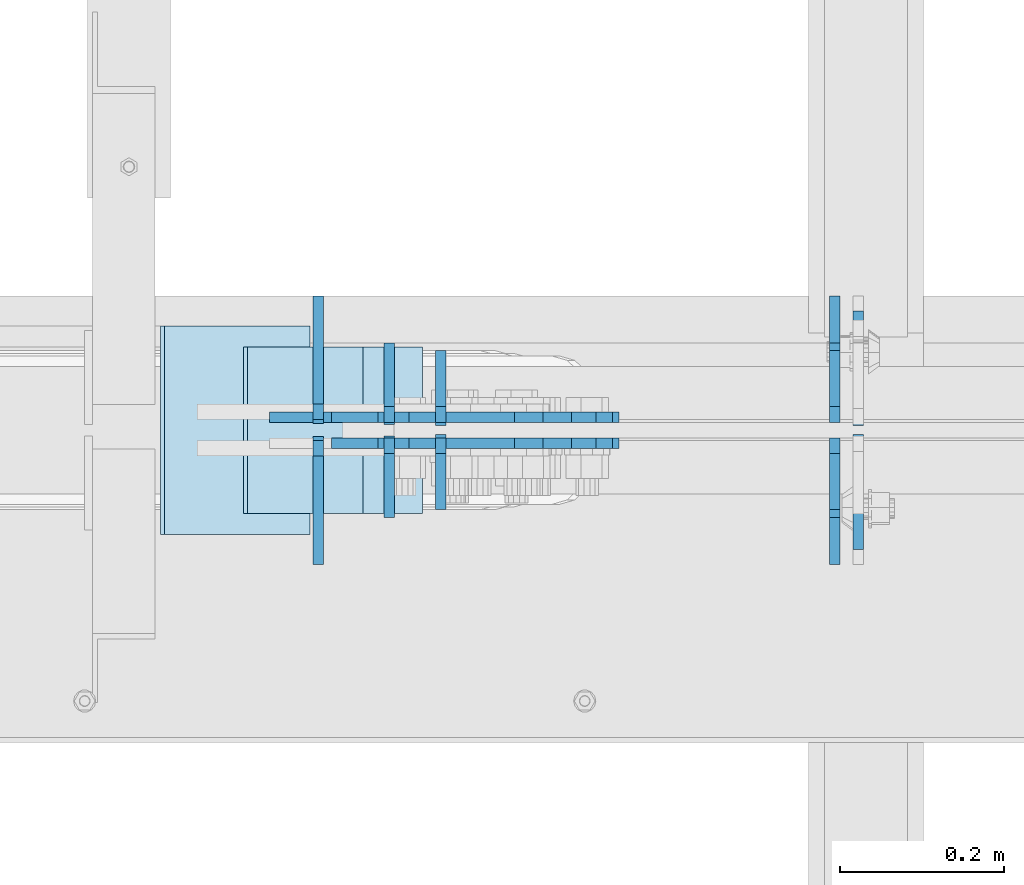
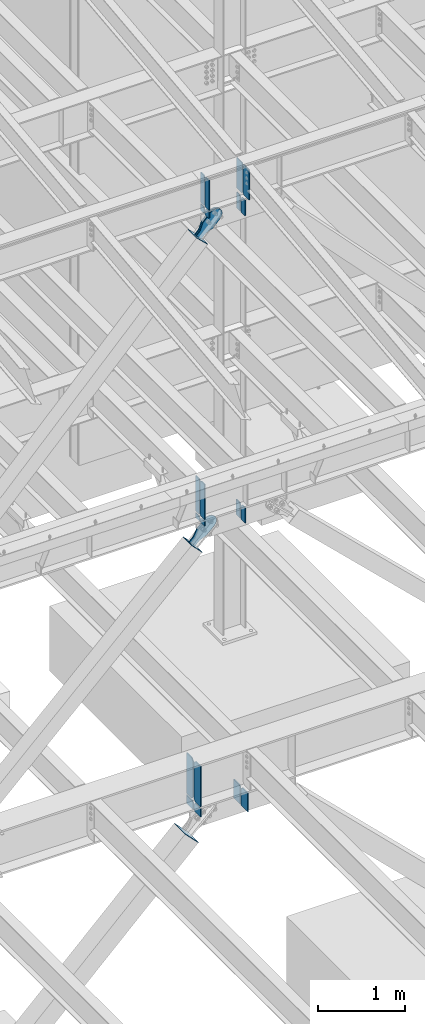
# One storey, part 1038 of 1179: 26 plates, 9 elements without a shape of their own.
"""IFC2X3 building model written with IfcOpenShell, lengths in millimetres."""

from ifc_helpers import new_model, si_unit, frame, origin_with_axes, place, context, subcontext, project, spatial, faceted_brep, material, type_object, element, aggregate, save


model = new_model("IFC2X3")

# Units and contexts
model_context = context("Model", 3, precision=1e-05, world=origin_with_axes())
body_context = subcontext(model_context, "Body", "Model", "MODEL_VIEW")
ifc_project = project(units=[si_unit("LENGTHUNIT", "METRE", prefix="MILLI"), si_unit("AREAUNIT", "SQUARE_METRE"), si_unit("VOLUMEUNIT", "CUBIC_METRE"), si_unit("MASSUNIT", "GRAM", prefix="KILO"), si_unit("TIMEUNIT", "SECOND"), si_unit("PLANEANGLEUNIT", "RADIAN"), si_unit("SOLIDANGLEUNIT", "STERADIAN"), si_unit("THERMODYNAMICTEMPERATUREUNIT", "DEGREE_CELSIUS"), si_unit("LUMINOUSINTENSITYUNIT", "LUMEN")], contexts=[model_context])

# Site, building, storey
site_placement = place(None, origin_with_axes())
site = spatial("IfcSite", under=ifc_project, at=site_placement, CompositionType="ELEMENT")
building_placement = place(site_placement, origin_with_axes())
building = spatial("IfcBuilding", under=site, at=building_placement, Name="Undefined", CompositionType="ELEMENT")
storey_placement = place(building_placement, origin_with_axes())
storey = spatial("IfcBuildingStorey", under=building, at=storey_placement, Name="Undefined", CompositionType="ELEMENT", Elevation=0.0)

# Assembly, plates
assembly_1_placement = place(storey_placement, origin_with_axes())
assembly_1 = element("IfcElementAssembly", 1, at=assembly_1_placement, inside=storey, Name="BEAM", AssemblyPlace="NOTDEFINED", PredefinedType="RIGID_FRAME")
ifc_material_1 = material(Name="STEEL/A572-GR.50")
plate_type_1 = type_object("IfcPlateType", PredefinedType="NOTDEFINED")
plate_1_placement = place(assembly_1_placement, frame((12398.375, 27045.4437499701, 11823.3031250357), z_axis=(0.0, 0.0, 1.0), x_axis=(0.0, -1.0, 0.0)))
plate_1 = element("IfcPlate", 2, at=plate_1_placement, type_object=plate_type_1, material=ifc_material_1, Name="PLATE", context=body_context, shape_type="Brep", body=[
    faceted_brep([(0.0, -6.34999999998763, 17.4624996185248), (0.0, -6.35000000000036, 407.98750038147), (0.0, 6.35000000000036, 407.98750038147), (0.0, 6.35000000000582, 17.4624996185175), (17.4624996185303, -6.35000000000036, 425.450000000001), (17.4624996185303, 6.35000000000036, 425.450000000001), (139.699999999997, -6.35000000000036, 425.450000000001), (139.699999999997, 6.35000000000036, 425.450000000001), (139.699999999997, -6.35000000000036, 0.0), (139.699999999997, 6.35000000000036, 0.0), (17.4624996185303, -6.34999999999309, 1.81898940354586e-12), (17.4624996185303, 6.34999999999854, -1.81898940354586e-12)], [[[0, 1, 2, 3]], [[1, 4, 5, 2]], [[4, 6, 7, 5]], [[6, 8, 9, 7]], [[8, 10, 11, 9]], [[10, 0, 3, 11]], [[5, 7, 9, 11, 3, 2]], [[10, 8, 6, 4, 1, 0]]]),
])
plate_2_placement = place(assembly_1_placement, frame((12398.375, 27056.5562499701, 11823.3031250357), z_axis=(0.0, 0.0, 1.0), x_axis=(0.0, 1.0, 0.0)))
plate_2 = element("IfcPlate", 3, at=plate_2_placement, type_object=plate_type_1, material=ifc_material_1, Name="PLATE", context=body_context, shape_type="Brep", body=[
    faceted_brep([(0.0, -6.34999999998763, 17.4624996185248), (0.0, -6.35000000000036, 407.98750038147), (0.0, 6.35000000000036, 407.98750038147), (0.0, 6.35000000000582, 17.4624996185175), (17.4624996185303, -6.35000000000036, 425.450000000001), (17.4624996185303, 6.35000000000036, 425.450000000001), (139.699999999997, -6.35000000000036, 425.450000000001), (139.699999999997, 6.35000000000036, 425.450000000001), (139.699999999997, -6.35000000000036, 0.0), (139.699999999997, 6.35000000000036, 0.0), (17.4624996185303, -6.34999999999309, 1.81898940354586e-12), (17.4624996185303, 6.34999999999854, -1.81898940354586e-12)], [[[0, 1, 2, 3]], [[1, 4, 5, 2]], [[4, 6, 7, 5]], [[6, 8, 9, 7]], [[8, 10, 11, 9]], [[10, 0, 3, 11]], [[5, 7, 9, 11, 3, 2]], [[10, 8, 6, 4, 1, 0]]]),
])

assembly_2_placement = place(storey_placement, origin_with_axes())
assembly_2 = element("IfcElementAssembly", 4, at=assembly_2_placement, inside=storey, Name="BEAM", AssemblyPlace="NOTDEFINED", PredefinedType="RIGID_FRAME")
plate_type_2 = type_object("IfcPlateType", PredefinedType="NOTDEFINED")
plate_3_placement = place(assembly_2_placement, frame((11826.7034918783, 27058.14375, 7489.825), z_axis=(0.0, 1.0, 0.0), x_axis=(0.0, 0.0, 1.0)))
plate_3 = element("IfcPlate", 5, at=plate_3_placement, type_object=plate_type_2, material=ifc_material_1, Name="PLATE", context=body_context, shape_type="Brep", body=[
    faceted_brep([(0.0, -6.34999999998763, 17.4624996185248), (0.0, -6.35000000000036, 99.21875), (0.0, 6.35000000000036, 99.21875), (0.0, 6.35000000000582, 17.4624996185175), (498.475, -6.35000000000036, 99.21875), (498.475, 6.35000000000036, 99.21875), (498.474999999775, -6.34999999979482, 17.4624996185303), (498.474999999769, 6.35000000019681, 17.4624996185303), (481.012500381255, -6.34999999980209, 0.0), (481.01250038125, 6.35000000019136, 0.0), (17.4624996185303, -6.34999999999309, 1.81898940354586e-12), (17.4624996185303, 6.34999999999854, -1.81898940354586e-12)], [[[0, 1, 2, 3]], [[1, 4, 5, 2]], [[4, 6, 7, 5]], [[6, 8, 9, 7]], [[8, 10, 11, 9]], [[10, 0, 3, 11]], [[5, 7, 9, 11, 3, 2]], [[10, 8, 6, 4, 1, 0]]]),
])
plate_4_placement = place(assembly_2_placement, frame((11826.7034918783, 27043.85625, 7489.825), z_axis=(0.0, -1.0, 0.0), x_axis=(0.0, 0.0, 1.0)))
plate_4 = element("IfcPlate", 6, at=plate_4_placement, type_object=plate_type_2, material=ifc_material_1, Name="PLATE", context=body_context, shape_type="Brep", body=[
    faceted_brep([(0.0, -6.34999999998763, 17.4624996185248), (0.0, -6.35000000000036, 99.21875), (0.0, 6.35000000000036, 99.21875), (0.0, 6.35000000000582, 17.4624996185175), (498.475, -6.35000000000036, 99.21875), (498.475, 6.35000000000036, 99.21875), (498.474999999775, -6.34999999979482, 17.4624996185303), (498.474999999769, 6.35000000019681, 17.4624996185303), (481.012500381255, -6.34999999980209, 0.0), (481.01250038125, 6.35000000019136, 0.0), (17.4624996185303, -6.34999999999309, 1.81898940354586e-12), (17.4624996185303, 6.34999999999854, -1.81898940354586e-12)], [[[0, 1, 2, 3]], [[1, 4, 5, 2]], [[4, 6, 7, 5]], [[6, 8, 9, 7]], [[8, 10, 11, 9]], [[10, 0, 3, 11]], [[5, 7, 9, 11, 3, 2]], [[10, 8, 6, 4, 1, 0]]]),
])

# Assembly, plate
assembly_3_placement = place(storey_placement, origin_with_axes())
assembly_3 = element("IfcElementAssembly", 7, at=assembly_3_placement, inside=storey, AssemblyPlace="NOTDEFINED", PredefinedType="RIGID_FRAME")
ifc_material_2 = material(Name="STEEL/A36")
plate_type_3 = type_object("IfcPlateType", PredefinedType="NOTDEFINED")
plate_5_placement = place(assembly_3_placement, frame((11822.52639044, 27066.875, 11394.5424549715), z_axis=(-0.724386095169387, 0.0, 0.689394506161203), x_axis=(0.689394506161203, 0.0, 0.724386095169387)))
plate_5 = element("IfcPlate", 8, at=plate_5_placement, type_object=plate_type_3, material=ifc_material_2, context=body_context, shape_type="Brep", body=[
    faceted_brep([(0.0, -6.34999999999854, 0.0), (-8.18545231595635e-11, -6.34999999999854, 91.5986124346418), (-8.18545231595635e-11, 6.34999999999854, 91.5986124346418), (0.0, 6.34999999999854, 0.0), (82.5500000001266, -6.34999999999854, 91.5986124347546), (82.5500000001266, 6.34999999999854, 91.5986124347546), (184.150000000493, -6.34999999999854, 136.286806217293), (184.150000000493, 6.34999999999854, 136.286806217293), (329.234985848627, -6.34999999999854, 136.286806217511), (329.234985848627, 6.34999999999854, 136.286806217511), (363.86305410257, -6.34999999999854, 129.398855183379), (363.86305410257, 6.34999999999854, 129.398855183379), (393.219312869078, -6.34999999999854, 109.783630186394), (393.219312869078, 6.34999999999854, 109.783630186394), (412.8345378661, -6.34999999999854, 80.4273714198789), (412.8345378661, 6.34999999999854, 80.4273714198789), (419.72248890029, -6.34999999999854, 45.7993092699908), (419.72248890029, 6.34999999999854, 45.7993092699908), (412.834537866132, -6.34999999999854, 11.171241015978), (412.834537866132, 6.34999999999854, 11.171241015978), (393.219312869132, -6.34999999999854, -18.1850177505985), (393.219312869132, 6.34999999999854, -18.1850177505985), (363.863054102636, -6.34999999999854, -37.8002427476786), (363.863054102636, 6.34999999999854, -37.8002427476786), (329.234988900062, -6.34999999999854, -44.6881937819198), (329.234988900062, 6.34999999999854, -44.6881937819198), (184.150000000598, -6.34999999999854, -44.6881937821345), (184.150000000598, 6.34999999999854, -44.6881937821345), (82.550000000203, -6.34999999999854, 1.2732925824821e-10), (82.550000000203, 6.34999999999854, 1.2732925824821e-10)], [[[0, 1, 2, 3]], [[1, 4, 5, 2]], [[4, 6, 7, 5]], [[6, 8, 9, 7]], [[8, 10, 11, 9]], [[10, 12, 13, 11]], [[12, 14, 15, 13]], [[14, 16, 17, 15]], [[16, 18, 19, 17]], [[18, 20, 21, 19]], [[20, 22, 23, 21]], [[22, 24, 25, 23]], [[24, 26, 27, 25]], [[26, 28, 29, 27]], [[28, 0, 3, 29]], [[5, 7, 9, 11, 13, 15, 17, 19, 21, 23, 25, 27, 29, 3, 2]], [[28, 26, 24, 22, 20, 18, 16, 14, 12, 10, 8, 6, 4, 1, 0]]]),
])
aggregate(assembly_3, [plate_5])

assembly_4_placement = place(storey_placement, origin_with_axes())
assembly_4 = element("IfcElementAssembly", 9, at=assembly_4_placement, inside=storey, AssemblyPlace="NOTDEFINED", PredefinedType="RIGID_FRAME")
plate_6_placement = place(assembly_4_placement, frame((11822.52639044, 27035.125, 11394.5424549715), z_axis=(-0.724386095169387, 0.0, 0.689394506161203), x_axis=(0.689394506161203, 0.0, 0.724386095169387)))
plate_6 = element("IfcPlate", 10, at=plate_6_placement, type_object=plate_type_3, material=ifc_material_2, context=body_context, shape_type="Brep", body=[
    faceted_brep([(0.0, -6.34999999999854, 0.0), (-8.18545231595635e-11, -6.34999999999854, 91.5986124346418), (-8.18545231595635e-11, 6.34999999999854, 91.5986124346418), (0.0, 6.34999999999854, 0.0), (82.5500000001266, -6.34999999999854, 91.5986124347546), (82.5500000001266, 6.34999999999854, 91.5986124347546), (184.150000000493, -6.34999999999854, 136.286806217293), (184.150000000493, 6.34999999999854, 136.286806217293), (329.234985848627, -6.34999999999854, 136.286806217511), (329.234985848627, 6.34999999999854, 136.286806217511), (363.86305410257, -6.34999999999854, 129.398855183379), (363.86305410257, 6.34999999999854, 129.398855183379), (393.219312869078, -6.34999999999854, 109.783630186394), (393.219312869078, 6.34999999999854, 109.783630186394), (412.8345378661, -6.34999999999854, 80.4273714198789), (412.8345378661, 6.34999999999854, 80.4273714198789), (419.72248890029, -6.34999999999854, 45.7993092699908), (419.72248890029, 6.34999999999854, 45.7993092699908), (412.834537866132, -6.34999999999854, 11.171241015978), (412.834537866132, 6.34999999999854, 11.171241015978), (393.219312869132, -6.34999999999854, -18.1850177505985), (393.219312869132, 6.34999999999854, -18.1850177505985), (363.863054102636, -6.34999999999854, -37.8002427476786), (363.863054102636, 6.34999999999854, -37.8002427476786), (329.234988900062, -6.34999999999854, -44.6881937819198), (329.234988900062, 6.34999999999854, -44.6881937819198), (184.150000000598, -6.34999999999854, -44.6881937821345), (184.150000000598, 6.34999999999854, -44.6881937821345), (82.550000000203, -6.34999999999854, 1.2732925824821e-10), (82.550000000203, 6.34999999999854, 1.2732925824821e-10)], [[[0, 1, 2, 3]], [[1, 4, 5, 2]], [[4, 6, 7, 5]], [[6, 8, 9, 7]], [[8, 10, 11, 9]], [[10, 12, 13, 11]], [[12, 14, 15, 13]], [[14, 16, 17, 15]], [[16, 18, 19, 17]], [[18, 20, 21, 19]], [[20, 22, 23, 21]], [[22, 24, 25, 23]], [[24, 26, 27, 25]], [[26, 28, 29, 27]], [[28, 0, 3, 29]], [[5, 7, 9, 11, 13, 15, 17, 19, 21, 23, 25, 27, 29, 3, 2]], [[28, 26, 24, 22, 20, 18, 16, 14, 12, 10, 8, 6, 4, 1, 0]]]),
])
aggregate(assembly_4, [plate_6])

assembly_5_placement = place(storey_placement, origin_with_axes())
assembly_5 = element("IfcElementAssembly", 11, at=assembly_5_placement, inside=storey, Name="Plate", AssemblyPlace="NOTDEFINED", PredefinedType="RIGID_FRAME")
plate_type_4 = type_object("IfcPlateType", PredefinedType="NOTDEFINED")
plate_7_placement = place(assembly_5_placement, frame((11865.1364646699, 26949.4, 11358.3736890884), z_axis=(-0.724386095169387, 0.0, 0.689394506161203), x_axis=(0.0, 1.0, 0.0)))
plate_7 = element("IfcPlate", 12, at=plate_7_placement, type_object=plate_type_4, material=ifc_material_2, Name="Plate", context=body_context, shape_type="Brep", body=[
    faceted_brep([(0.0, -3.17500000000109, 0.0), (0.0, -3.17500000000291, 203.200000000368), (0.0, 3.17499999998836, 203.200000000361), (0.0, 3.17500000000109, 7.27595761418343e-12), (203.199999999997, -3.17500000000291, 203.200000000368), (203.199999999997, 3.17499999998836, 203.200000000361), (203.199999999997, -3.17499999999927, 3.63797880709171e-12), (203.199999999997, 3.17499999999382, -3.63797880709171e-12)], [[[0, 1, 2, 3]], [[1, 4, 5, 2]], [[4, 6, 7, 5]], [[6, 0, 3, 7]], [[5, 7, 3, 2]], [[6, 4, 1, 0]]]),
])
aggregate(assembly_5, [plate_7])

assembly_6_placement = place(storey_placement, origin_with_axes())
assembly_6 = element("IfcElementAssembly", 13, at=assembly_6_placement, inside=storey, Name="Plate", AssemblyPlace="NOTDEFINED", PredefinedType="RIGID_FRAME")
plate_8_placement = place(assembly_6_placement, frame((11792.592114219, 26949.4, 7040.69890381545), z_axis=(-0.694497308871752, 0.0, 0.719495300867138), x_axis=(0.0, 1.0, 0.0)))
plate_8 = element("IfcPlate", 14, at=plate_8_placement, type_object=plate_type_4, material=ifc_material_2, Name="Plate", context=body_context, shape_type="Brep", body=[
    faceted_brep([(0.0, -3.17500000000109, 0.0), (0.0, -3.17500000000291, 203.200000000368), (0.0, 3.17499999998836, 203.200000000361), (0.0, 3.17500000000109, 7.27595761418343e-12), (203.199999999997, -3.17500000000291, 203.200000000368), (203.199999999997, 3.17499999998836, 203.200000000361), (203.199999999997, -3.17499999999927, 3.63797880709171e-12), (203.199999999997, 3.17499999999382, -3.63797880709171e-12)], [[[0, 1, 2, 3]], [[1, 4, 5, 2]], [[4, 6, 7, 5]], [[6, 0, 3, 7]], [[5, 7, 3, 2]], [[6, 4, 1, 0]]]),
])
aggregate(assembly_6, [plate_8])

# Plate
plate_type_5 = type_object("IfcPlateType", PredefinedType="NOTDEFINED")
plate_9_placement = place(assembly_1_placement, frame((11889.5047145402, 27056.5562499701, 11823.3031250357), z_axis=(0.0, 1.0, 0.0), x_axis=(0.0, 0.0, 1.0)))
plate_9 = element("IfcPlate", 15, at=plate_9_placement, type_object=plate_type_5, material=ifc_material_1, Name="PLATE", context=body_context, shape_type="Brep", body=[
    faceted_brep([(0.0, -6.34999999998763, 17.4624996185248), (0.0, -6.35000000000036, 91.28125), (0.0, 6.35000000000036, 91.28125), (0.0, 6.35000000000582, 17.4624996185175), (425.450000000001, -6.35000000000036, 91.28125), (425.450000000001, 6.35000000000036, 91.28125), (425.450000000001, -6.35000000000036, 17.4624996185303), (425.450000000001, 6.35000000000036, 17.4624996185303), (407.98750038147, -6.35000000000036, 0.0), (407.98750038147, 6.35000000000036, 0.0), (17.4624996185303, -6.34999999999309, 1.81898940354586e-12), (17.4624996185303, 6.34999999999854, -1.81898940354586e-12)], [[[0, 1, 2, 3]], [[1, 4, 5, 2]], [[4, 6, 7, 5]], [[6, 8, 9, 7]], [[8, 10, 11, 9]], [[10, 0, 3, 11]], [[5, 7, 9, 11, 3, 2]], [[10, 8, 6, 4, 1, 0]]]),
])

plate_10_placement = place(assembly_1_placement, frame((11889.5047145402, 27045.4437499701, 11823.3031250357), z_axis=(0.0, -1.0, 0.0), x_axis=(0.0, 0.0, 1.0)))
plate_10 = element("IfcPlate", 16, at=plate_10_placement, type_object=plate_type_5, material=ifc_material_1, Name="PLATE", context=body_context, shape_type="Brep", body=[
    faceted_brep([(0.0, -6.34999999998763, 17.4624996185248), (0.0, -6.35000000000036, 91.28125), (0.0, 6.35000000000036, 91.28125), (0.0, 6.35000000000582, 17.4624996185175), (425.450000000001, -6.35000000000036, 91.28125), (425.450000000001, 6.35000000000036, 91.28125), (425.450000000001, -6.35000000000036, 17.4624996185303), (425.450000000001, 6.35000000000036, 17.4624996185303), (407.98750038147, -6.35000000000036, 0.0), (407.98750038147, 6.35000000000036, 0.0), (17.4624996185303, -6.34999999999309, 1.81898940354586e-12), (17.4624996185303, 6.34999999999854, -1.81898940354586e-12)], [[[0, 1, 2, 3]], [[1, 4, 5, 2]], [[4, 6, 7, 5]], [[6, 8, 9, 7]], [[8, 10, 11, 9]], [[10, 0, 3, 11]], [[5, 7, 9, 11, 3, 2]], [[10, 8, 6, 4, 1, 0]]]),
])

plate_type_6 = type_object("IfcPlateType", PredefinedType="NOTDEFINED")
plate_11_placement = place(assembly_1_placement, frame((11889.5047145402, 27060.5249999701, 11802.6656250357), z_axis=(0.0, 1.0, 0.0), x_axis=(0.0, 0.0, -1.0)))
plate_11 = element("IfcPlate", 17, at=plate_11_placement, type_object=plate_type_6, material=ifc_material_1, Name="PLATE", context=body_context, shape_type="Brep", body=[
    faceted_brep([(0.0, 6.35000000000036, 19.0499999999993), (19.0500000000002, 6.35000000000036, 0.0), (19.0500000000002, -6.35000000000036, 0.0), (0.0, -6.35000000000036, 19.0499999999993), (0.0, -6.35000000000036, 87.3125), (0.0, 6.35000000000036, 87.3125), (87.061476451885, -6.35000000000036, 87.3125), (87.061476451885, 6.35000000000036, 87.3125), (87.061476451885, -6.35000000000036, 0.0), (87.061476451885, 6.35000000000036, 0.0)], [[[0, 1, 2, 3]], [[4, 5, 0, 3]], [[4, 6, 7, 5]], [[6, 8, 9, 7]], [[9, 8, 2, 1]], [[5, 7, 9, 1, 0]], [[8, 6, 4, 3, 2]]]),
])

plate_12_placement = place(assembly_1_placement, frame((11889.5047145402, 27041.4749999701, 11802.6656250357), z_axis=(0.0, -1.0, 0.0), x_axis=(0.0, 0.0, -1.0)))
plate_12 = element("IfcPlate", 18, at=plate_12_placement, type_object=plate_type_6, material=ifc_material_1, Name="PLATE", context=body_context, shape_type="Brep", body=[
    faceted_brep([(0.0, 6.35000000000036, 19.0499999999993), (19.0500000000002, 6.35000000000036, 0.0), (19.0500000000002, -6.35000000000036, 0.0), (0.0, -6.35000000000036, 19.0499999999993), (0.0, -6.35000000000036, 87.3125), (0.0, 6.35000000000036, 87.3125), (87.061476451885, -6.35000000000036, 87.3125), (87.061476451885, 6.35000000000036, 87.3125), (87.061476451885, -6.35000000000036, 0.0), (87.061476451885, 6.35000000000036, 0.0)], [[[0, 1, 2, 3]], [[4, 5, 0, 3]], [[4, 6, 7, 5]], [[6, 8, 9, 7]], [[9, 8, 2, 1]], [[5, 7, 9, 1, 0]], [[8, 6, 4, 3, 2]]]),
])

plate_13_placement = place(assembly_1_placement, frame((12369.8, 27060.5249999701, 11581.2197369183), z_axis=(0.0, 1.0, 0.0), x_axis=(0.0, 0.0, 1.0)))
plate_13 = element("IfcPlate", 19, at=plate_13_placement, type_object=plate_type_6, material=ifc_material_1, Name="PLATE", context=body_context, shape_type="Brep", body=[
    faceted_brep([(221.4458881174, -6.35000000000036, 19.0499999999993), (202.3958881174, -6.35000000000036, 0.0), (202.3958881174, 6.35000000000036, 0.0), (221.4458881174, 6.35000000000036, 19.0499999999993), (0.0, -6.34999999999854, 0.0), (0.0, -6.35000000000036, 87.3125), (0.0, 6.35000000000036, 87.3125), (0.0, 6.34999999999854, 0.0), (221.4458881174, -6.35000000000036, 87.3125), (221.4458881174, 6.35000000000036, 87.3125)], [[[0, 1, 2, 3]], [[4, 5, 6, 7]], [[5, 8, 9, 6]], [[9, 8, 0, 3]], [[4, 7, 2, 1]], [[7, 6, 9, 3, 2]], [[8, 5, 4, 1, 0]]]),
])

plate_14_placement = place(assembly_1_placement, frame((12369.8, 27041.4749999701, 11581.2197369183), z_axis=(0.0, -1.0, 0.0), x_axis=(0.0, 0.0, 1.0)))
plate_14 = element("IfcPlate", 20, at=plate_14_placement, type_object=plate_type_6, material=ifc_material_1, Name="PLATE", context=body_context, shape_type="Brep", body=[
    faceted_brep([(221.4458881174, -6.35000000000036, 19.0499999999993), (202.3958881174, -6.35000000000036, 0.0), (202.3958881174, 6.35000000000036, 0.0), (221.4458881174, 6.35000000000036, 19.0499999999993), (0.0, -6.34999999999854, 0.0), (0.0, -6.35000000000036, 87.3125), (0.0, 6.35000000000036, 87.3125), (0.0, 6.34999999999854, 0.0), (221.4458881174, -6.35000000000036, 87.3125), (221.4458881174, 6.35000000000036, 87.3125)], [[[0, 1, 2, 3]], [[4, 5, 6, 7]], [[5, 8, 9, 6]], [[9, 8, 0, 3]], [[4, 7, 2, 1]], [[7, 6, 9, 3, 2]], [[8, 5, 4, 1, 0]]]),
])

aggregate(assembly_1, [plate_11, plate_12, plate_9, plate_10, plate_1, plate_2, plate_13, plate_14])

plate_type_7 = type_object("IfcPlateType", PredefinedType="NOTDEFINED")
plate_15_placement = place(assembly_2_placement, frame((11826.7034918783, 27060.525, 7464.42499999926), z_axis=(0.0, 1.0, 0.0), x_axis=(0.0, 0.0, -1.0)))
plate_15 = element("IfcPlate", 21, at=plate_15_placement, type_object=plate_type_7, material=ifc_material_1, Name="PLATE", context=body_context, shape_type="Brep", body=[
    faceted_brep([(0.0, 6.35000000000036, 19.0499999999993), (19.0500000000002, 6.35000000000036, 0.0), (19.0500000000002, -6.35000000000036, 0.0), (0.0, -6.35000000000036, 19.0499999999993), (0.0, -6.35000000000036, 96.8374999999978), (0.0, 6.35000000000036, 96.8374999999978), (66.4559488542145, -6.35000000000036, 96.8374999999978), (66.4559488542145, 6.35000000000036, 96.8374999999978), (66.4559488542145, -6.35000000000036, 0.0), (66.4559488542145, 6.35000000000036, 0.0)], [[[0, 1, 2, 3]], [[4, 5, 0, 3]], [[4, 6, 7, 5]], [[6, 8, 9, 7]], [[9, 8, 2, 1]], [[5, 7, 9, 1, 0]], [[8, 6, 4, 3, 2]]]),
])

plate_16_placement = place(assembly_2_placement, frame((11826.7034918783, 27041.475, 7464.42499999926), z_axis=(0.0, -1.0, 0.0), x_axis=(0.0, 0.0, -1.0)))
plate_16 = element("IfcPlate", 22, at=plate_16_placement, type_object=plate_type_7, material=ifc_material_1, Name="PLATE", context=body_context, shape_type="Brep", body=[
    faceted_brep([(0.0, 6.35000000000036, 19.0499999999993), (19.0500000000002, 6.35000000000036, 0.0), (19.0500000000002, -6.35000000000036, 0.0), (0.0, -6.35000000000036, 19.0499999999993), (0.0, -6.35000000000036, 96.8374999999978), (0.0, 6.35000000000036, 96.8374999999978), (66.4559488542145, -6.35000000000036, 96.8374999999978), (66.4559488542145, 6.35000000000036, 96.8374999999978), (66.4559488542145, -6.35000000000036, 0.0), (66.4559488542145, 6.35000000000036, 0.0)], [[[0, 1, 2, 3]], [[4, 5, 0, 3]], [[4, 6, 7, 5]], [[6, 8, 9, 7]], [[9, 8, 2, 1]], [[5, 7, 9, 1, 0]], [[8, 6, 4, 3, 2]]]),
])

plate_type_8 = type_object("IfcPlateType", PredefinedType="NOTDEFINED")
plate_17_placement = place(assembly_2_placement, frame((12369.8000016846, 27060.525, 7251.87907645959), z_axis=(0.0, 1.0, 0.0), x_axis=(0.0, 0.0, 1.0)))
plate_17 = element("IfcPlate", 23, at=plate_17_placement, type_object=plate_type_8, material=ifc_material_1, Name="PLATE", context=body_context, shape_type="Brep", body=[
    faceted_brep([(212.545923540411, -6.35000000000036, 19.0499999999993), (193.49592354041, -6.35000000000036, 0.0), (193.49592354041, 6.35000000000036, 0.0), (212.545923540411, 6.35000000000036, 19.0499999999993), (0.0, -6.34999999999854, 0.0), (0.0, -6.35000000000036, 96.8374999999978), (0.0, 6.35000000000036, 96.8374999999978), (0.0, 6.34999999999854, 0.0), (212.545923540411, -6.35000000000036, 96.8374999999978), (212.545923540411, 6.35000000000036, 96.8374999999978)], [[[0, 1, 2, 3]], [[4, 5, 6, 7]], [[5, 8, 9, 6]], [[9, 8, 0, 3]], [[4, 7, 2, 1]], [[7, 6, 9, 3, 2]], [[8, 5, 4, 1, 0]]]),
])

plate_18_placement = place(assembly_2_placement, frame((12369.8000016846, 27041.475, 7251.87907645959), z_axis=(0.0, -1.0, 0.0), x_axis=(0.0, 0.0, 1.0)))
plate_18 = element("IfcPlate", 24, at=plate_18_placement, type_object=plate_type_8, material=ifc_material_1, Name="PLATE", context=body_context, shape_type="Brep", body=[
    faceted_brep([(212.545923540411, -6.35000000000036, 19.0499999999993), (193.49592354041, -6.35000000000036, 0.0), (193.49592354041, 6.35000000000036, 0.0), (212.545923540411, 6.35000000000036, 19.0499999999993), (0.0, -6.34999999999854, 0.0), (0.0, -6.35000000000036, 96.8374999999978), (0.0, 6.35000000000036, 96.8374999999978), (0.0, 6.34999999999854, 0.0), (212.545923540411, -6.35000000000036, 96.8374999999978), (212.545923540411, 6.35000000000036, 96.8374999999978)], [[[0, 1, 2, 3]], [[4, 5, 6, 7]], [[5, 8, 9, 6]], [[9, 8, 0, 3]], [[4, 7, 2, 1]], [[7, 6, 9, 3, 2]], [[8, 5, 4, 1, 0]]]),
])

aggregate(assembly_2, [plate_15, plate_16, plate_3, plate_4, plate_17, plate_18])

# Assembly, plates
assembly_7_placement = place(storey_placement, origin_with_axes())
assembly_7 = element("IfcElementAssembly", 25, at=assembly_7_placement, inside=storey, Name="BEAM", AssemblyPlace="NOTDEFINED", PredefinedType="RIGID_FRAME")
plate_type_9 = type_object("IfcPlateType", PredefinedType="NOTDEFINED")
plate_19_placement = place(assembly_7_placement, frame((11739.9593751867, 26890.6625, 3505.2), z_axis=(0.0, 0.0, 1.0), x_axis=(0.0, 1.0, 0.0)))
plate_19 = element("IfcPlate", 26, at=plate_19_placement, type_object=plate_type_9, material=ifc_material_1, Name="PLATE", context=body_context, shape_type="Brep", body=[
    faceted_brep([(0.0, -6.34999999999854, 0.0), (0.0, -6.35000000000036, 571.5), (0.0, 6.35000000000036, 571.5), (0.0, 6.34999999999854, 0.0), (117.475000762941, -6.35000000000036, 571.5), (117.475000762941, 6.35000000000036, 571.5), (152.400000000001, -6.35000000000036, 536.575000762939), (152.400000000001, 6.35000000000036, 536.575000762939), (152.400000000001, -6.35000000000036, 34.9249992370605), (152.400000000001, 6.35000000000036, 34.9249992370605), (117.475000762941, -6.35000000000036, 0.0), (117.475000762941, 6.35000000000036, 0.0)], [[[0, 1, 2, 3]], [[1, 4, 5, 2]], [[4, 6, 7, 5]], [[6, 8, 9, 7]], [[8, 10, 11, 9]], [[10, 0, 3, 11]], [[5, 7, 9, 11, 3, 2]], [[10, 8, 6, 4, 1, 0]]]),
])
plate_20_placement = place(assembly_7_placement, frame((11739.9593751867, 27058.9375, 3505.2), z_axis=(0.0, 0.0, 1.0), x_axis=(0.0, 1.0, 0.0)))
plate_20 = element("IfcPlate", 27, at=plate_20_placement, type_object=plate_type_9, material=ifc_material_1, Name="PLATE", context=body_context, shape_type="Brep", body=[
    faceted_brep([(0.0, -6.35000000000036, 34.9249992370605), (0.0, -6.35000000000036, 536.575000762939), (0.0, 6.35000000000036, 536.575000762939), (0.0, 6.35000000000036, 34.9249992370605), (34.9249992370605, -6.35000000000036, 571.5), (34.9249992370605, 6.35000000000036, 571.5), (152.400000000001, -6.35000000000036, 571.5), (152.400000000001, 6.35000000000036, 571.5), (152.400000000001, -6.35000000000036, 0.0), (152.400000000001, 6.35000000000036, 0.0), (34.9249992370605, -6.35000000000036, 0.0), (34.9249992370605, 6.35000000000036, 0.0)], [[[0, 1, 2, 3]], [[1, 4, 5, 2]], [[4, 6, 7, 5]], [[6, 8, 9, 7]], [[8, 10, 11, 9]], [[10, 0, 3, 11]], [[5, 7, 9, 11, 3, 2]], [[10, 8, 6, 4, 1, 0]]]),
])
plate_type_10 = type_object("IfcPlateType", PredefinedType="NOTDEFINED")
plate_21_placement = place(assembly_7_placement, frame((11739.9433815895, 27063.7, 3479.8), z_axis=(0.0, 1.0, 0.0), x_axis=(0.0, 0.0, -1.0)))
plate_21 = element("IfcPlate", 28, at=plate_21_placement, type_object=plate_type_10, material=ifc_material_1, Name="PLATE", context=body_context, shape_type="Brep", body=[
    faceted_brep([(0.0, -6.35000000000036, 19.0499999999993), (0.0, -6.35000000000036, 150.8125), (0.0, 6.35000000000036, 150.8125), (0.0, 6.35000000000036, 19.0499999999993), (114.654452531247, -6.35000000000036, 150.8125), (114.654452531247, 6.35000000000036, 150.8125), (114.654452531247, -6.35000000000036, 0.0), (114.654452531247, 6.35000000000036, 0.0), (19.0500000000002, -6.35000000000036, 0.0), (19.0500000000002, 6.35000000000036, 0.0)], [[[0, 1, 2, 3]], [[1, 4, 5, 2]], [[4, 6, 7, 5]], [[6, 8, 9, 7]], [[3, 9, 8, 0]], [[5, 7, 9, 3, 2]], [[8, 6, 4, 1, 0]]]),
])
plate_22_placement = place(assembly_7_placement, frame((11739.9433815895, 27038.3, 3479.8), z_axis=(0.0, -1.0, 0.0), x_axis=(0.0, 0.0, -1.0)))
plate_22 = element("IfcPlate", 29, at=plate_22_placement, type_object=plate_type_10, material=ifc_material_1, Name="PLATE", context=body_context, shape_type="Brep", body=[
    faceted_brep([(0.0, -6.35000000000036, 19.0499999999993), (0.0, -6.35000000000036, 150.8125), (0.0, 6.35000000000036, 150.8125), (0.0, 6.35000000000036, 19.0499999999993), (114.654452531247, -6.35000000000036, 150.8125), (114.654452531247, 6.35000000000036, 150.8125), (114.654452531247, -6.35000000000036, 0.0), (114.654452531247, 6.35000000000036, 0.0), (19.0500000000002, -6.35000000000036, 0.0), (19.0500000000002, 6.35000000000036, 0.0)], [[[0, 1, 2, 3]], [[1, 4, 5, 2]], [[4, 6, 7, 5]], [[6, 8, 9, 7]], [[3, 9, 8, 0]], [[5, 7, 9, 3, 2]], [[8, 6, 4, 1, 0]]]),
])

# Assembly, plate
assembly_8_placement = place(storey_placement, origin_with_axes())
assembly_8 = element("IfcElementAssembly", 30, at=assembly_8_placement, inside=storey, AssemblyPlace="NOTDEFINED", PredefinedType="RIGID_FRAME")
plate_type_11 = type_object("IfcPlateType", PredefinedType="NOTDEFINED")
plate_23_placement = place(assembly_8_placement, frame((11758.7028563309, 27066.875, 7071.23633215706), z_axis=(-0.694497308871752, 0.0, 0.719495300867138), x_axis=(0.719495300867139, 0.0, 0.694497308871752)))
plate_23 = element("IfcPlate", 31, at=plate_23_placement, type_object=plate_type_11, material=ifc_material_2, context=body_context, shape_type="Brep", body=[
    faceted_brep([(0.0, -6.34999999999854, 0.0), (-4.35647962149233e-10, -6.34999999999854, 112.184930806416), (-4.35647962149233e-10, 6.34999999999854, 112.184930806416), (0.0, 6.34999999999854, 0.0), (82.5499999996491, -6.34999999999854, 112.184930806461), (82.5499999996491, 6.34999999999854, 112.184930806461), (184.149999999618, -6.34999999999854, 149.75496540347), (184.149999999618, 6.34999999999854, 149.75496540347), (327.919242323534, -6.34999999999854, 149.754965403559), (327.919242323534, 6.34999999999854, 149.754965403559), (363.762328723451, -6.34999999999854, 142.625332233587), (363.762328723451, 6.34999999999854, 142.625332233587), (394.148630137406, -6.34999999999854, 122.321854743475), (394.148630137406, 6.34999999999854, 122.321854743475), (414.452107627645, -6.34999999999854, 91.9355533295929), (414.452107627645, 6.34999999999854, 91.9355533295929), (421.581740797776, -6.34999999999854, 56.0924638777396), (421.581740797776, 6.34999999999854, 56.0924638777396), (414.452107627878, -6.34999999999854, 20.2493774776722), (414.452107627878, 6.34999999999854, 20.2493774776722), (394.14863013775, -6.34999999999854, -10.1369239363994), (394.14863013775, 6.34999999999854, -10.1369239363994), (363.762328723789, -6.34999999999854, -30.4404014266784), (363.762328723789, 6.34999999999854, -30.4404014266784), (327.919240798041, -6.34999999999854, -37.570034596738), (327.919240798041, 6.34999999999854, -37.570034596738), (184.150000000338, -6.34999999999854, -37.5700345968289), (184.150000000338, 6.34999999999854, -37.5700345968289), (82.550000000203, -6.34999999999854, 1.2732925824821e-10), (82.550000000203, 6.34999999999854, 1.2732925824821e-10)], [[[0, 1, 2, 3]], [[1, 4, 5, 2]], [[4, 6, 7, 5]], [[6, 8, 9, 7]], [[8, 10, 11, 9]], [[10, 12, 13, 11]], [[12, 14, 15, 13]], [[14, 16, 17, 15]], [[16, 18, 19, 17]], [[18, 20, 21, 19]], [[20, 22, 23, 21]], [[22, 24, 25, 23]], [[24, 26, 27, 25]], [[26, 28, 29, 27]], [[28, 0, 3, 29]], [[5, 7, 9, 11, 13, 15, 17, 19, 21, 23, 25, 27, 29, 3, 2]], [[28, 26, 24, 22, 20, 18, 16, 14, 12, 10, 8, 6, 4, 1, 0]]]),
])
aggregate(assembly_8, [plate_23])

assembly_9_placement = place(storey_placement, origin_with_axes())
assembly_9 = element("IfcElementAssembly", 32, at=assembly_9_placement, inside=storey, Name="Plate", AssemblyPlace="NOTDEFINED", PredefinedType="RIGID_FRAME")
plate_type_12 = type_object("IfcPlateType", PredefinedType="NOTDEFINED")
plate_24_placement = place(assembly_9_placement, frame((11727.9582005868, 26924.0, 2984.26305491211), z_axis=(-0.699860687134476, 0.0, 0.714279370137245), x_axis=(0.0, 1.0, 0.0)))
plate_24 = element("IfcPlate", 33, at=plate_24_placement, type_object=plate_type_12, material=ifc_material_2, Name="Plate", context=body_context, shape_type="Brep", body=[
    faceted_brep([(0.0, -3.17500000000109, 0.0), (0.0, -3.17499999986103, 253.99999999967), (0.0, 3.17500000013752, 253.999999999668), (0.0, 3.17500000000109, 7.27595761418343e-12), (254.0, -3.17499999986103, 253.99999999967), (254.0, 3.17500000013752, 253.999999999668), (254.0, -3.17500000000109, 9.09494701772928e-13), (254.0, 3.17499999999745, -1.36424205265939e-12)], [[[0, 1, 2, 3]], [[1, 4, 5, 2]], [[4, 6, 7, 5]], [[6, 0, 3, 7]], [[5, 7, 3, 2]], [[6, 4, 1, 0]]]),
])
aggregate(assembly_9, [plate_24])

# Plate
plate_type_13 = type_object("IfcPlateType", PredefinedType="NOTDEFINED")
plate_25_placement = place(assembly_7_placement, frame((12369.8000001867, 27063.7, 3479.8), z_axis=(0.0, 1.0, 0.0), x_axis=(0.0, 0.0, -1.0)))
plate_25 = element("IfcPlate", 34, at=plate_25_placement, type_object=plate_type_13, material=ifc_material_1, Name="PLATE", context=body_context, shape_type="Brep", body=[
    faceted_brep([(0.0, -6.35000000000036, 19.0499999999993), (0.0, -6.35000000000036, 150.8125), (0.0, 6.35000000000036, 150.8125), (0.0, 6.35000000000036, 19.0499999999993), (263.877901732164, -6.35000000000036, 150.8125), (263.877901732164, 6.35000000000036, 150.8125), (263.877901732164, -6.35000000000036, 0.0), (263.877901732164, 6.35000000000036, 0.0), (19.0500000000002, -6.35000000000036, 0.0), (19.0500000000002, 6.35000000000036, 0.0)], [[[0, 1, 2, 3]], [[1, 4, 5, 2]], [[4, 6, 7, 5]], [[6, 8, 9, 7]], [[3, 9, 8, 0]], [[5, 7, 9, 3, 2]], [[8, 6, 4, 1, 0]]]),
])

plate_26_placement = place(assembly_7_placement, frame((12369.8000001867, 27038.3, 3479.8), z_axis=(0.0, -1.0, 0.0), x_axis=(0.0, 0.0, -1.0)))
plate_26 = element("IfcPlate", 35, at=plate_26_placement, type_object=plate_type_13, material=ifc_material_1, Name="PLATE", context=body_context, shape_type="Brep", body=[
    faceted_brep([(0.0, -6.35000000000036, 19.0499999999993), (0.0, -6.35000000000036, 150.8125), (0.0, 6.35000000000036, 150.8125), (0.0, 6.35000000000036, 19.0499999999993), (263.877901732164, -6.35000000000036, 150.8125), (263.877901732164, 6.35000000000036, 150.8125), (263.877901732164, -6.35000000000036, 0.0), (263.877901732164, 6.35000000000036, 0.0), (19.0500000000002, -6.35000000000036, 0.0), (19.0500000000002, 6.35000000000036, 0.0)], [[[0, 1, 2, 3]], [[1, 4, 5, 2]], [[4, 6, 7, 5]], [[6, 8, 9, 7]], [[3, 9, 8, 0]], [[5, 7, 9, 3, 2]], [[8, 6, 4, 1, 0]]]),
])

aggregate(assembly_7, [plate_19, plate_20, plate_21, plate_22, plate_25, plate_26])

save(model, "model.ifc")
